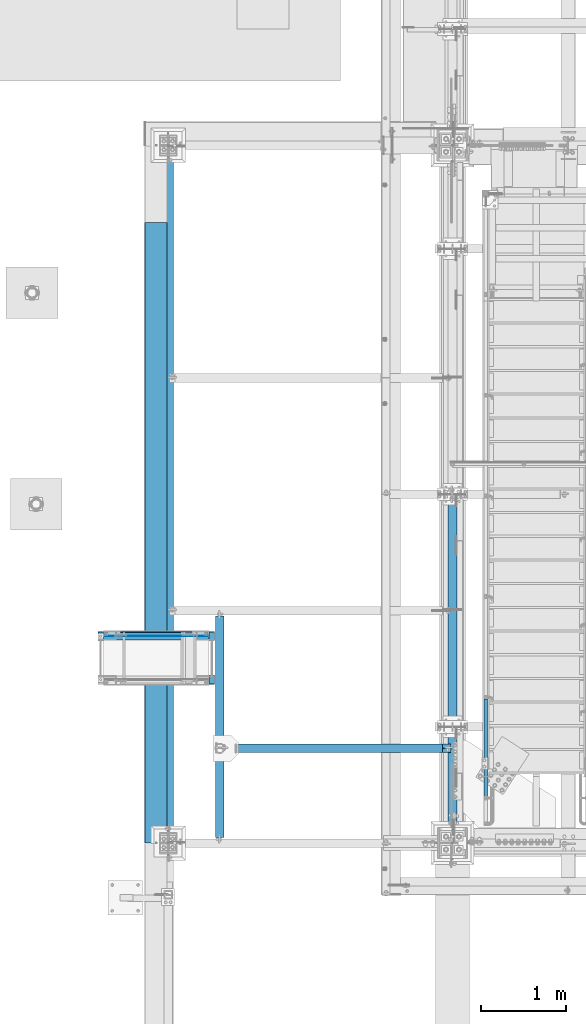
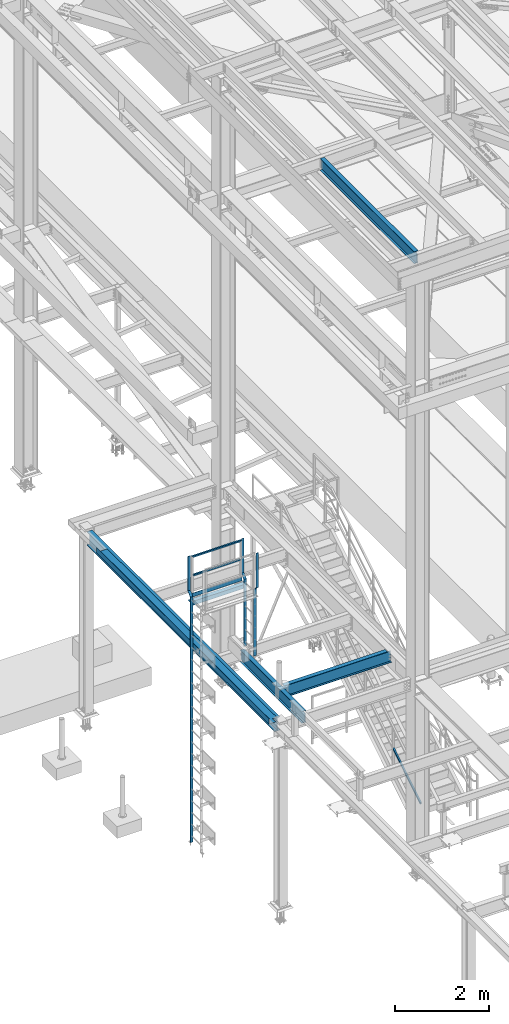
# One storey, part 1741 of 3843: 12 beams, 1 member, 9 elements without a shape of their own.
"""IFC2X3 building model written with IfcOpenShell, lengths in millimetres."""

from ifc_helpers import new_model, si_unit, frame, origin_with_axes, place, context, subcontext, project, spatial, faceted_brep, material, type_object, element, aggregate, save


model = new_model("IFC2X3")

# Units and contexts
model_context = context("Model", 3, precision=1e-05, world=origin_with_axes())
body_context = subcontext(model_context, "Body", "Model", "MODEL_VIEW")
ifc_project = project(units=[si_unit("LENGTHUNIT", "METRE", prefix="MILLI"), si_unit("AREAUNIT", "SQUARE_METRE"), si_unit("VOLUMEUNIT", "CUBIC_METRE"), si_unit("MASSUNIT", "GRAM", prefix="KILO"), si_unit("TIMEUNIT", "SECOND"), si_unit("PLANEANGLEUNIT", "RADIAN"), si_unit("SOLIDANGLEUNIT", "STERADIAN"), si_unit("THERMODYNAMICTEMPERATUREUNIT", "DEGREE_CELSIUS"), si_unit("LUMINOUSINTENSITYUNIT", "LUMEN")], contexts=[model_context])

# Site, building, storey
site_placement = place(None, origin_with_axes())
site = spatial("IfcSite", under=ifc_project, at=site_placement, CompositionType="ELEMENT")
building_placement = place(site_placement, origin_with_axes())
building = spatial("IfcBuilding", under=site, at=building_placement, Name="Undefined", CompositionType="ELEMENT")
storey_placement = place(building_placement, origin_with_axes())
storey = spatial("IfcBuildingStorey", under=building, at=storey_placement, Name="Undefined", CompositionType="ELEMENT", Elevation=0.0)

# Assembly, beams
assembly_1_placement = place(storey_placement, origin_with_axes())
assembly_1 = element("IfcElementAssembly", 1, at=assembly_1_placement, inside=storey, Name="RAIL", AssemblyPlace="NOTDEFINED", PredefinedType="RIGID_FRAME")
ifc_material_1 = material()
beam_type_1 = type_object("IfcBeamType", Name="HSS1-1/2X1-1/2X1/4", PredefinedType="NOTDEFINED")
beam_1_placement = place(assembly_1_placement, frame((32489.179674793, 28079.7, 37330.7272224447), z_axis=(0.0, -1.0, 0.0), x_axis=(1.0, 0.0, 0.0)))
beam_1 = element("IfcBeam", 2, at=beam_1_placement, type_object=beam_type_1, material=ifc_material_1, Name="RAIL", ObjectType="HSS1-1/2X1-1/2X1/4", context=body_context, shape_type="Brep", body=[
    faceted_brep([(19.0499992350015, 12.6999993299978, -12.6999993299978), (19.0499992350015, -12.6999993299978, -12.6999993299978), (1164.62970173694, -12.6999993299978, -12.6999993300014), (1164.62970173694, 12.6999993299978, -12.6999993300014), (19.0499992350015, -12.6999993299978, 12.6999993299978), (1164.62970173694, -12.6999993299978, 12.6999993300014), (19.0499992350015, 12.6999993299978, 12.6999993299978), (1164.62970173694, 12.6999993299978, 12.6999993300014), (19.0499992350015, 19.0499992350015, -19.0499992350015), (19.0499992350015, 19.0499992350015, 19.0499992350015), (1164.62970173694, 19.0499992350015, 19.0499992350015), (1164.62970173694, 19.0499992350015, -19.0499992350015), (19.0499992350015, -19.0499992350015, 19.0499992350015), (1164.62970173694, -19.0499992350015, 19.0499992350015), (19.0499992350015, -19.0499992350015, -19.0499992350015), (1164.62970173694, -19.0499992350015, -19.0499992350015)], [[[0, 1, 2, 3]], [[1, 4, 5, 2]], [[4, 6, 7, 5]], [[6, 0, 3, 7]], [[8, 9, 10, 11]], [[9, 12, 13, 10]], [[12, 14, 15, 13]], [[14, 8, 11, 15]], [[13, 15, 11, 10], [5, 7, 3, 2]], [[14, 12, 9, 8], [6, 4, 1, 0]]]),
])
beam_2_placement = place(assembly_1_placement, frame((32387.6686576823, 28079.6999999999, 37812.7905159017), z_axis=(0.0, -1.0, 0.0), x_axis=(1.0, 0.0, 0.0)))
beam_2 = element("IfcBeam", 3, at=beam_2_placement, type_object=beam_type_1, material=ifc_material_1, Name="RAIL", ObjectType="HSS1-1/2X1-1/2X1/4", context=body_context, shape_type="Brep", body=[
    faceted_brep([(88.8110177807284, 12.6999993299978, -12.6999993300014), (114.211016440731, -12.6999993299978, -12.6999993300014), (1272.49071875267, -12.6999993299978, -12.6999993300014), (1297.89071741267, 12.6999993299978, -12.6999993300014), (114.211016440731, -12.6999993299978, 12.6999993300014), (1272.49071875267, -12.6999993299978, 12.6999993300014), (88.8110177807284, 12.6999993299978, 12.6999993300014), (1297.89071741267, 12.6999993299978, 12.6999993300014), (82.4610178757284, 19.0499992350015, -19.0499992350015), (82.4610178757284, 19.0499992350015, 19.0499992350015), (1304.24071731767, 19.0499992350015, 19.0499992350015), (1304.24071731767, 19.0499992350015, -19.0499992350015), (120.561016345731, -19.0499992350015, 19.0499992350015), (1266.14071884767, -19.0499992350015, 19.0499992350015), (120.561016345731, -19.0499992350015, -19.0499992350015), (1266.14071884767, -19.0499992350015, -19.0499992350015)], [[[0, 1, 2, 3]], [[1, 4, 5, 2]], [[4, 6, 7, 5]], [[6, 0, 3, 7]], [[8, 9, 10, 11]], [[9, 12, 13, 10]], [[12, 14, 15, 13]], [[14, 8, 11, 15]], [[13, 15, 11, 10], [5, 7, 3, 2]], [[14, 12, 9, 8], [6, 4, 1, 0]]]),
])

# Assembly, member
assembly_2_placement = place(storey_placement, origin_with_axes())
assembly_2 = element("IfcElementAssembly", 4, at=assembly_2_placement, inside=storey, Name="RAIL", AssemblyPlace="NOTDEFINED", PredefinedType="RIGID_FRAME")
member_type = type_object("IfcMemberType", Name="HSS1-1/2X1-1/2X1/4", PredefinedType="NOTDEFINED")
member_placement = place(assembly_2_placement, frame((36969.699999953, 26149.3, 31013.4000000005), z_axis=(0.0, -0.529007926750979, 0.848616882600523), x_axis=(0.0, 0.848616882600524, 0.529007926750978)))
member = element("IfcMember", 5, at=member_placement, type_object=member_type, material=ifc_material_1, Name="RAIL", ObjectType="HSS1-1/2X1-1/2X1/4", context=body_context, shape_type="Brep", body=[
    faceted_brep([(1388.70393079125, -19.0500003643538, 19.0499992334262), (1364.95328239725, -19.0499992350015, -19.0499992364712), (1364.95328239725, 19.0499992350015, -19.0499992364712), (1388.70393079125, 19.0499992350015, 19.0499992334262), (1384.74548929282, -12.6999993299978, 12.699999328448), (1384.74548929282, 12.6999993299978, 12.699999328448), (1368.91172389637, 12.6999993299978, -12.6999993314894), (1368.91172389637, -12.6999993299978, -12.6999993314894), (10.5729683018217, 19.0499992350015, -19.0499992349742), (34.3236166958304, 19.0499992350015, 19.0499992349305), (34.3236166958304, -19.0500000222455, 19.0499992349305), (10.5729683018217, -19.0499992350015, -19.0499992349742), (30.3651751973375, -12.6999993299978, 12.6999993299451), (14.5314098008821, -12.6999993299978, -12.6999993299924), (14.5314098008821, 12.6999993299978, -12.6999993299924), (30.3651751973375, 12.6999993299978, 12.6999993299451)], [[[0, 1, 2, 3], [4, 5, 6, 7]], [[8, 9, 3, 2]], [[9, 10, 0, 3]], [[10, 11, 1, 0]], [[11, 8, 2, 1]], [[10, 9, 8, 11], [12, 13, 14, 15]], [[13, 12, 4, 7]], [[14, 13, 7, 6]], [[15, 14, 6, 5]], [[12, 15, 5, 4]]]),
])
aggregate(assembly_2, [member])

# Assembly, beams
assembly_3_placement = place(storey_placement, origin_with_axes())
assembly_3 = element("IfcElementAssembly", 6, at=assembly_3_placement, inside=storey, Name="LADDER", AssemblyPlace="NOTDEFINED", PredefinedType="RIGID_FRAME")
ifc_material_2 = material(Name="STEEL/A36")
beam_type_2 = type_object("IfcBeamType", PredefinedType="NOTDEFINED")
beam_3_placement = place(assembly_3_placement, frame((33736.4390258789, 28109.8624999999, 37831.8405151367), z_axis=(-1.0, 0.0, 0.0), x_axis=(0.0, 0.0, -1.0)))
beam_3 = element("IfcBeam", 7, at=beam_3_placement, type_object=beam_type_2, material=ifc_material_2, Name="LADDER", context=body_context, shape_type="Brep", body=[
    faceted_brep([(0.0, -4.76249999999709, -31.75), (0.0, -4.76249999999709, 31.75), (0.0, 4.76249999999709, 31.75), (0.0, 4.76249999999709, -31.75), (888.999999999985, 4.76249999999709, 31.75), (888.999999999985, 4.76249999999709, -31.75), (892.945384181585, -4.76249999999709, -31.75), (892.945384181585, -4.76249999999709, 31.75), (990.599999999991, 106.362500000003, 31.75), (990.599999999991, 106.362500000003, -31.75), (994.545384181591, 96.8375000000087, -31.75), (994.545384181591, 96.8375000000087, 31.75), (2723.62203281296, 106.362499999999, 31.75), (2723.62203281296, 106.362499999999, -31.75), (2723.62203281296, 96.8374999999978, 31.75), (2723.62203281296, 96.8374999999978, -31.75)], [[[0, 1, 2, 3]], [[3, 2, 4, 5]], [[1, 0, 6, 7]], [[5, 4, 8, 9]], [[7, 6, 10, 11]], [[9, 8, 12, 13]], [[8, 4, 2, 1, 7, 11, 14, 12]], [[11, 10, 15, 14]], [[10, 6, 0, 3, 5, 9, 13, 15]], [[14, 15, 13, 12]]]),
])
beam_4_placement = place(assembly_3_placement, frame((33736.4390258789, 27592.3374999999, 35108.2184823238), z_axis=(-1.0, 0.0, 0.0), x_axis=(0.0, 0.0, 1.0)))
beam_4 = element("IfcBeam", 8, at=beam_4_placement, type_object=beam_type_2, material=ifc_material_2, Name="LADDER", context=body_context, shape_type="Brep", body=[
    faceted_brep([(0.0, -4.76249999999709, -31.75), (0.0, -4.76249999999709, 31.75), (0.0, 4.76249999999709, 31.75), (0.0, 4.76249999999709, -31.75), (1733.02203281297, 4.76250000000073, 31.75), (1733.02203281297, 4.76250000000073, -31.75), (1729.07664863137, -4.76250000000073, -31.75), (1729.07664863137, -4.76250000000073, 31.75), (1834.62203281298, -96.8374999999978, 31.75), (1834.62203281298, -96.8374999999978, -31.75), (1830.67664863138, -106.362499999999, -31.75), (1830.67664863138, -106.362499999999, 31.75), (2723.62203281296, -96.8374999999978, 31.75), (2723.62203281296, -96.8374999999978, -31.75), (2723.62203281296, -106.362499999999, 31.75), (2723.62203281296, -106.362499999999, -31.75)], [[[0, 1, 2, 3]], [[3, 2, 4, 5]], [[1, 0, 6, 7]], [[5, 4, 8, 9]], [[7, 6, 10, 11]], [[9, 8, 12, 13]], [[8, 4, 2, 1, 7, 11, 14, 12]], [[11, 10, 15, 14]], [[10, 6, 0, 3, 5, 9, 13, 15]], [[14, 15, 13, 12]]]),
])
aggregate(assembly_3, [beam_3, beam_4])

# Assembly, beam
assembly_4_placement = place(storey_placement, origin_with_axes())
assembly_4 = element("IfcElementAssembly", 9, at=assembly_4_placement, inside=storey, Name="LADDER", AssemblyPlace="NOTDEFINED", PredefinedType="RIGID_FRAME")
beam_5_placement = place(assembly_4_placement, frame((32425.7733459473, 28008.2624999999, 30492.7), z_axis=(1.0, 0.0, 0.0), x_axis=(0.0, 0.0, 1.0)))
beam_5 = element("IfcBeam", 10, at=beam_5_placement, type_object=beam_type_2, material=ifc_material_2, Name="LADDER", context=body_context, shape_type="Brep", body=[
    faceted_brep([(0.0, -4.76249999999709, -31.75), (0.0, -4.76249999999709, 31.75), (0.0, 4.76249999999709, 31.75), (0.0, 4.76249999999709, -31.75), (6348.54051513673, 4.76250000000073, 31.75), (6348.54051513673, 4.76250000000073, -31.75), (6344.59513095513, -4.76250000000073, -31.75), (6344.59513095513, -4.76250000000073, 31.75), (6450.14051513673, -96.8374999999978, 31.75), (6450.14051513673, -96.8374999999978, -31.75), (6446.19513095513, -106.362499999999, -31.75), (6446.19513095513, -106.362499999999, 31.75), (7339.14051513672, -96.8374999999978, 31.75), (7339.14051513672, -96.8374999999978, -31.75), (7339.14051513672, -106.362499999999, 31.75), (7339.14051513672, -106.362499999999, -31.75)], [[[0, 1, 2, 3]], [[3, 2, 4, 5]], [[1, 0, 6, 7]], [[5, 4, 8, 9]], [[7, 6, 10, 11]], [[9, 8, 12, 13]], [[8, 4, 2, 1, 7, 11, 14, 12]], [[11, 10, 15, 14]], [[10, 6, 0, 3, 5, 9, 13, 15]], [[14, 15, 13, 12]]]),
])
aggregate(assembly_4, [beam_5])

# Beam
beam_type_3 = type_object("IfcBeamType", PredefinedType="NOTDEFINED")
beam_6_placement = place(assembly_1_placement, frame((32470.2063863546, 28057.475000765, 36835.4260559082), z_axis=(0.0, 0.0, 1.0), x_axis=(1.0, 0.0, 0.0)))
beam_6 = element("IfcBeam", 11, at=beam_6_placement, type_object=beam_type_3, material=ifc_material_2, Name="TOE_PLATE", context=body_context, shape_type="Brep", body=[
    faceted_brep([(0.0, 3.17500000000291, -50.8000000000029), (0.0, 3.17500000000291, 50.8000000000029), (1221.7796976298, 3.17499999999927, 50.8000000000029), (1221.7796976298, 3.17499999999927, -50.8000000000029), (0.0, -3.17500000000291, 50.8000000000029), (1221.7796976298, -3.17499999999927, 50.8000000000029), (0.0, -3.17500000000291, -50.8000000000029), (1221.7796976298, -3.17499999999927, -50.8000000000029)], [[[0, 1, 2, 3]], [[1, 4, 5, 2]], [[4, 6, 7, 5]], [[6, 0, 3, 7]], [[5, 7, 3, 2]], [[6, 4, 1, 0]]]),
])

aggregate(assembly_1, [beam_6, beam_1, beam_2])

# Assembly, beam
assembly_5_placement = place(storey_placement, origin_with_axes())
assembly_5 = element("IfcElementAssembly", 12, at=assembly_5_placement, inside=storey, Name="ANGLE", AssemblyPlace="NOTDEFINED", PredefinedType="RIGID_FRAME")
beam_type_4 = type_object("IfcBeamType", Name="L4X4X3/8", PredefinedType="NOTDEFINED")
beam_7_placement = place(assembly_5_placement, frame((32400.3733459473, 28063.8249999999, 36651.275958252), z_axis=(0.0, 0.0, -1.0), x_axis=(1.0, 0.0, 0.0)))
beam_7 = element("IfcBeam", 13, at=beam_7_placement, type_object=beam_type_4, material=ifc_material_2, Name="ANGLE", ObjectType="L4X4X3/8", context=body_context, shape_type="Brep", body=[
    faceted_brep([(0.0, 50.8000000000029, -50.8000000000029), (0.0, 50.8000000000029, 50.8000000000029), (1361.47970020696, 50.7999999999993, 50.8000000000029), (1361.47970020696, 50.7999999999993, -50.8000000000029), (0.0, 41.2750000000015, 50.8000000000029), (1361.47970020696, 41.2750000000015, 50.8000000000029), (0.0, 41.2749999999942, -41.2750000000015), (1361.47970020696, 41.2750000000015, -41.2750000000015), (0.0, -50.8000000000029, -41.2750000000015), (1361.47970020696, -50.7999999999993, -41.2750000000015), (0.0, -50.8000000000029, -50.8000000000029), (1361.47970020696, -50.7999999999993, -50.8000000000029)], [[[0, 1, 2, 3]], [[1, 4, 5, 2]], [[4, 6, 7, 5]], [[6, 8, 9, 7]], [[8, 10, 11, 9]], [[10, 0, 3, 11]], [[5, 7, 9, 11, 3, 2]], [[10, 8, 6, 4, 1, 0]]]),
])
aggregate(assembly_5, [beam_7])

assembly_6_placement = place(storey_placement, origin_with_axes())
assembly_6 = element("IfcElementAssembly", 14, at=assembly_6_placement, inside=storey, Name="BEAM", AssemblyPlace="NOTDEFINED", PredefinedType="RIGID_FRAME")
ifc_material_3 = material(Name="STEEL/A992")
beam_type_5 = type_object("IfcBeamType", Name="W12X19", PredefinedType="NOTDEFINED")
beam_8_placement = place(assembly_6_placement, frame((33832.8, 26733.5, 34656.7125), z_axis=(0.0, 0.0, 1.0), x_axis=(1.0, 0.0, 0.0)))
beam_8 = element("IfcBeam", 15, at=beam_8_placement, type_object=beam_type_5, material=ifc_material_3, Name="BEAM", ObjectType="W12X19", context=body_context, shape_type="Brep", body=[
    faceted_brep([(15.8750000000146, -3.17500000000291, -128.587499998961), (15.8750000000146, 3.17500000000291, -128.587499998961), (92.0750001907509, 3.17499999999927, -128.587499999987), (92.0750001907509, -3.17499999999927, -128.587499999987), (96.9350797087973, 3.17499999999927, -129.554229922578), (96.9350797087973, -3.17499999999927, -129.554229922578), (101.055256176951, 3.17499999999927, -132.307243823052), (101.055256176951, -3.17499999999927, -132.307243823052), (103.808270077425, 3.17499999999927, -136.427420291206), (103.808270077425, -3.17499999999927, -136.427420291206), (104.775000000016, -3.17499999999927, -141.287499809252), (104.775000000016, 3.17499999999927, -141.287499809252), (104.775000000016, 3.17499999999927, -144.462500000001), (104.775000000016, 50.7999999999993, -144.462500000001), (104.775000000016, 50.7999999999993, -153.987500000003), (104.775000000016, -50.7999999999993, -153.987500000003), (104.775000000016, -50.7999999999993, -144.462500000001), (104.775000000016, -3.17499999999927, -144.462500000001), (2624.1375, 50.7999999999993, 144.462500000001), (2624.1375, 3.17499999999927, 144.462500000001), (104.775000000016, 3.17499999999927, 144.462500000001), (104.775000000016, 50.7999999999993, 144.462500000001), (92.0750001907509, -3.17499999999927, 128.587500000016), (92.0750001907509, 3.17499999999927, 128.587500000016), (15.8750000000146, 3.17500000000291, 128.587500001042), (15.8750000000146, -3.17500000000291, 128.587500001042), (96.9350797087973, -3.17499999999927, 129.554229922607), (96.9350797087973, 3.17499999999927, 129.554229922607), (101.055256176951, -3.17499999999927, 132.307243823081), (101.055256176951, 3.17499999999927, 132.307243823081), (103.808270077425, -3.17499999999927, 136.427420291235), (103.808270077425, 3.17499999999927, 136.427420291235), (104.775000000016, -3.17499999999927, 141.287499809281), (104.775000000016, 3.17499999999927, 141.287499809281), (2624.1375, -50.7999999999993, 153.987500000003), (2624.1375, 50.7999999999993, 153.987500000003), (104.775000000016, 50.7999999999993, 153.987500000003), (104.775000000016, -50.7999999999993, 153.987500000003), (2624.1375, -50.7999999999993, 144.462500000001), (104.775000000016, -50.7999999999993, 144.462500000001), (2624.1375, -3.17499999999927, 144.462500000001), (104.775000000016, -3.17499999999927, 144.462500000001), (2624.1375, -3.17499999999927, 134.937499809261), (2624.1375, 3.17499999999927, 134.937499809261), (2625.1042299226, -3.17499999999927, 130.077420291214), (2625.1042299226, 3.17499999999927, 130.077420291214), (2627.85724382307, -3.17499999999927, 125.957243823061), (2627.85724382307, 3.17499999999927, 125.957243823061), (2631.97742029122, -3.17499999999927, 123.204229922587), (2631.97742029122, 3.17499999999927, 123.204229922587), (2636.83749980927, -3.17499999999927, 122.237499999996), (2636.83749980927, 3.17499999999927, 122.237499999996), (2725.73750000001, -3.17499999999927, 122.237499999996), (2725.73750000001, 3.17499999999927, 122.237499999996), (2725.73750000001, -3.17499999999927, -144.462500000001), (2725.73750000001, -50.7999999999993, -144.462500000001), (2725.73750000001, -50.7999999999993, -153.987500000003), (2725.73750000001, 50.7999999999993, -153.987500000003), (2725.73750000001, 50.7999999999993, -144.462500000001), (2725.73750000001, 3.17499999999927, -144.462500000001), (2725.73750000001, 3.17499999999927, -114.712500000001), (2725.73750000001, 3.17499999999927, 115.887499999997)], [[[0, 1, 2, 3]], [[3, 2, 4, 5]], [[5, 4, 6, 7]], [[7, 6, 8, 9]], [[10, 11, 12, 13, 14, 15, 16, 17]], [[9, 8, 11, 10]], [[18, 19, 20, 21]], [[22, 23, 24, 25]], [[26, 27, 23, 22]], [[28, 29, 27, 26]], [[30, 31, 29, 28]], [[32, 33, 31, 30]], [[34, 35, 36, 37]], [[38, 34, 37, 39]], [[40, 38, 39, 41]], [[37, 36, 21, 20, 33, 32, 41, 39]], [[35, 18, 21, 36]], [[34, 38, 40, 42, 43, 19, 18, 35]], [[44, 45, 43, 42]], [[46, 47, 45, 44]], [[48, 49, 47, 46]], [[50, 51, 49, 48]], [[52, 53, 51, 50]], [[54, 55, 56, 57, 58, 59, 60, 61, 53, 52]], [[55, 54, 17, 16]], [[56, 55, 16, 15]], [[57, 56, 15, 14]], [[58, 57, 14, 13]], [[59, 58, 13, 12]], [[6, 4, 2, 1, 24, 23, 27, 29, 31, 33, 20, 19, 43, 45, 47, 49, 51, 53, 61, 60, 59, 12, 11, 8]], [[25, 24, 1, 0]], [[54, 52, 50, 48, 46, 44, 42, 40, 41, 32, 30, 28, 26, 22, 25, 0, 3, 5, 7, 9, 10, 17]]]),
])
aggregate(assembly_6, [beam_8])

assembly_7_placement = place(storey_placement, origin_with_axes())
assembly_7 = element("IfcElementAssembly", 16, at=assembly_7_placement, inside=storey, Name="BEAM", AssemblyPlace="NOTDEFINED", PredefinedType="RIGID_FRAME")
beam_9_placement = place(assembly_7_placement, frame((33832.8, 25615.9, 34656.7125), z_axis=(0.0, 0.0, 1.0), x_axis=(0.0, 1.0, 0.0)))
beam_9 = element("IfcBeam", 17, at=beam_9_placement, type_object=beam_type_5, material=ifc_material_3, Name="BEAM", ObjectType="W12X19", context=body_context, shape_type="Brep", body=[
    faceted_brep([(2679.69999999999, -3.17500000000291, -144.462500000001), (2679.69999999999, -50.8000000000029, -144.462500000001), (2679.69999999999, -50.8000000000029, -153.987500000003), (2679.69999999999, 50.8000000000029, -153.987500000003), (2679.69999999999, 50.8000000000029, -144.462500000001), (2679.69999999999, 3.17500000000291, -144.462500000001), (2679.69999999999, 3.17500000000291, -141.287499809252), (2679.69999999999, -3.17500000000291, -141.287499809252), (2680.66672992258, 3.17500000000291, -136.427420291206), (2680.66672992258, -3.17500000000291, -136.427420291206), (2683.41974382306, 3.17500000000291, -132.307243823052), (2683.41974382306, -3.17500000000291, -132.307243823052), (2687.53992029121, 3.17500000000291, -129.554229922578), (2687.53992029121, -3.17500000000291, -129.554229922578), (2692.39999980926, 3.17500000000291, -128.587499999987), (2692.39999980926, -3.17500000000291, -128.587499999987), (2727.32499999999, -3.17500000000291, -128.587499999987), (2727.32499999999, 3.17500000000291, -128.587499999987), (2679.69999999999, 50.8000000000029, 144.462500000001), (2679.69999999999, 3.17500000000291, 144.462500000001), (63.4999999999927, 3.17500000000291, 144.462500000001), (63.4999999999927, 50.8000000000029, 144.462500000001), (63.4999999999927, -3.17500000000291, -141.287499809267), (63.4999999999927, 3.17500000000291, -141.287499809267), (63.4999999999927, 3.17500000000291, -144.462500000001), (63.4999999999927, 50.8000000000029, -144.462500000001), (63.4999999999927, 50.8000000000029, -153.987500000003), (63.4999999999927, -50.8000000000029, -153.987500000003), (63.4999999999927, -50.8000000000029, -144.462500000001), (63.4999999999927, -3.17500000000291, -144.462500000001), (62.5332700774052, -3.17500000000291, -136.42742029122), (62.5332700774052, 3.17500000000291, -136.42742029122), (59.7802561769277, -3.17500000000291, -132.307243823067), (59.7802561769277, 3.17500000000291, -132.307243823067), (55.660079708774, -3.17500000000291, -129.554229922593), (55.660079708774, 3.17500000000291, -129.554229922593), (50.8000001907276, -3.17500000000291, -128.587500000001), (50.8000001907276, 3.17500000000291, -128.587500000001), (15.8750000000146, -3.17500000000291, -128.587499998961), (15.8750000000146, 3.17500000000291, -128.587499998961), (15.8750000000146, -3.17500000000291, 128.587500001042), (15.8750000000146, 3.17500000000291, 128.587500001042), (15.8750000000146, 3.17500000000291, 115.887500001612), (15.8750000000146, 3.17500000000291, -114.712499998386), (50.8000001907276, -3.17500000000291, 128.587500000001), (50.8000001907276, 3.17500000000291, 128.587500000001), (55.660079708774, -3.17500000000291, 129.554229922593), (55.660079708774, 3.17500000000291, 129.554229922593), (59.7802561769277, -3.17500000000291, 132.307243823067), (59.7802561769277, 3.17500000000291, 132.307243823067), (62.5332700774052, -3.17500000000291, 136.42742029122), (62.5332700774052, 3.17500000000291, 136.42742029122), (63.4999999999927, -3.17500000000291, 141.287499809267), (63.4999999999927, 3.17500000000291, 141.287499809267), (2679.69999999999, -50.8000000000029, 153.987500000003), (2679.69999999999, 50.8000000000029, 153.987500000003), (63.4999999999927, 50.8000000000029, 153.987500000003), (63.4999999999927, -50.8000000000029, 153.987500000003), (2679.69999999999, -50.8000000000029, 144.462500000001), (63.4999999999927, -50.8000000000029, 144.462500000001), (2679.69999999999, -3.17500000000291, 144.462500000001), (63.4999999999927, -3.17500000000291, 144.462500000001), (2679.69999999999, -3.17500000000291, 141.287499809281), (2679.69999999999, 3.17500000000291, 141.287499809281), (2680.66672992258, -3.17500000000291, 136.427420291235), (2680.66672992258, 3.17500000000291, 136.427420291235), (2683.41974382306, -3.17500000000291, 132.307243823081), (2683.41974382306, 3.17500000000291, 132.307243823081), (2687.53992029121, -3.17500000000291, 129.554229922607), (2687.53992029121, 3.17500000000291, 129.554229922607), (2692.39999980926, -3.17500000000291, 128.587500000016), (2692.39999980926, 3.17500000000291, 128.587500000016), (2727.32499999999, -3.17500000000291, 128.587500000016), (2727.32499999999, 3.17500000000291, 128.587500000016), (2727.32499999999, 3.17500000000291, -114.712500000001), (2727.32499999999, 3.17500000000291, 115.887499999997)], [[[0, 1, 2, 3, 4, 5, 6, 7]], [[7, 6, 8, 9]], [[9, 8, 10, 11]], [[11, 10, 12, 13]], [[13, 12, 14, 15]], [[16, 15, 14, 17]], [[18, 19, 20, 21]], [[22, 23, 24, 25, 26, 27, 28, 29]], [[30, 31, 23, 22]], [[32, 33, 31, 30]], [[34, 35, 33, 32]], [[36, 37, 35, 34]], [[38, 39, 37, 36]], [[40, 41, 42, 43, 39, 38]], [[44, 45, 41, 40]], [[46, 47, 45, 44]], [[48, 49, 47, 46]], [[50, 51, 49, 48]], [[52, 53, 51, 50]], [[54, 55, 56, 57]], [[58, 54, 57, 59]], [[60, 58, 59, 61]], [[57, 56, 21, 20, 53, 52, 61, 59]], [[55, 18, 21, 56]], [[54, 58, 60, 62, 63, 19, 18, 55]], [[64, 65, 63, 62]], [[66, 67, 65, 64]], [[68, 69, 67, 66]], [[70, 71, 69, 68]], [[72, 73, 71, 70]], [[74, 75, 73, 72, 16, 17]], [[12, 10, 8, 6, 5, 24, 23, 31, 33, 35, 37, 39, 43, 42, 41, 45, 47, 49, 51, 53, 20, 19, 63, 65, 67, 69, 71, 73, 75, 74, 17, 14]], [[25, 24, 5, 4]], [[26, 25, 4, 3]], [[27, 26, 3, 2]], [[28, 27, 2, 1]], [[29, 28, 1, 0]], [[72, 70, 68, 66, 64, 62, 60, 61, 52, 50, 48, 46, 44, 40, 38, 36, 34, 32, 30, 22, 29, 0, 7, 9, 11, 13, 15, 16]]]),
])
aggregate(assembly_7, [beam_9])

assembly_8_placement = place(storey_placement, origin_with_axes())
assembly_8 = element("IfcElementAssembly", 18, at=assembly_8_placement, inside=storey, Name="BEAM", AssemblyPlace="NOTDEFINED", PredefinedType="RIGID_FRAME")
beam_10_placement = place(assembly_8_placement, frame((36575.9999999188, 25485.725, 45575.6071293685), z_axis=(0.0, 0.0, 1.0), x_axis=(0.0, 1.0, 0.0)))
beam_10 = element("IfcBeam", 19, at=beam_10_placement, type_object=beam_type_5, material=ifc_material_3, Name="BEAM", ObjectType="W12X19", context=body_context, shape_type="Brep", body=[
    faceted_brep([(146.049999999974, -3.17500000000291, -128.587499998903), (146.049999999974, 3.17500000000291, -128.587499998903), (184.150000190708, 3.17500000000291, -128.587499998903), (184.150000190708, -3.17500000000291, -128.587499998903), (189.010079708754, 3.17500000000291, -129.554229921494), (189.010079708754, -3.17500000000291, -129.554229921494), (193.130256176908, 3.17500000000291, -132.307243821968), (193.130256176908, -3.17500000000291, -132.307243821968), (195.883270077386, 3.17500000000291, -136.427420290122), (195.883270077386, -3.17500000000291, -136.427420290122), (196.849999999973, -3.17500000000291, -141.287499808168), (196.849999999973, 3.17500000000291, -141.287499808168), (196.849999999973, 3.17500000000291, -144.462500000001), (196.849999999973, 50.8000000000029, -144.462500000001), (196.849999999973, 50.8000000000029, -153.987500000003), (196.849999999973, -50.8000000000029, -153.987500000003), (196.849999999973, -50.8000000000029, -144.462500000001), (196.849999999973, -3.17500000000291, -144.462500000001), (4178.29999999988, 50.8000000000029, 144.462500000001), (4178.29999999988, 3.17500000000291, 144.462500000001), (196.849999999973, 3.17500000000291, 144.462500000001), (196.849999999973, 50.8000000000029, 144.462500000001), (184.150000190708, -3.17500000000291, 128.5875000011), (184.150000190708, 3.17500000000291, 128.5875000011), (146.049999999974, 3.17500000000291, 128.5875000011), (146.049999999974, -3.17500000000291, 128.5875000011), (189.010079708754, -3.17500000000291, 129.554229923691), (189.010079708754, 3.17500000000291, 129.554229923691), (193.130256176908, -3.17500000000291, 132.307243824165), (193.130256176908, 3.17500000000291, 132.307243824165), (195.883270077386, -3.17500000000291, 136.427420292319), (195.883270077386, 3.17500000000291, 136.427420292319), (196.849999999973, -3.17500000000291, 141.287499810365), (196.849999999973, 3.17500000000291, 141.287499810365), (4178.29999999988, -50.8000000000029, 153.987500000003), (4178.29999999988, 50.8000000000029, 153.987500000003), (196.849999999973, 50.8000000000029, 153.987500000003), (196.849999999973, -50.8000000000029, 153.987500000003), (4178.29999999988, -50.8000000000029, 144.462500000001), (196.849999999973, -50.8000000000029, 144.462500000001), (4178.29999999988, -3.17500000000291, 144.462500000001), (196.849999999973, -3.17500000000291, 144.462500000001), (4178.29999999988, -3.17500000000291, 141.287499810365), (4178.29999999988, 3.17500000000291, 141.287499810365), (4179.26672992246, -3.17500000000291, 136.427420292319), (4179.26672992246, 3.17500000000291, 136.427420292319), (4182.01974382294, -3.17500000000291, 132.307243824165), (4182.01974382294, 3.17500000000291, 132.307243824165), (4186.13992029109, -3.17500000000291, 129.554229923691), (4186.13992029109, 3.17500000000291, 129.554229923691), (4190.99999980914, -3.17500000000291, 128.5875000011), (4190.99999980914, 3.17500000000291, 128.5875000011), (4229.09999999987, -3.17500000000291, 128.5875000011), (4229.09999999987, 3.17500000000291, 128.5875000011), (4229.09999999987, 3.17500000000291, -114.712499998386), (4229.09999999987, 3.17500000000291, 115.887500001612), (4229.09999999987, -3.17500000000291, -128.587499998903), (4229.09999999987, 3.17500000000291, -128.587499998903), (4190.99999980914, -3.17500000000291, -128.587499998903), (4190.99999980914, 3.17500000000291, -128.587499998903), (4186.13992029109, -3.17500000000291, -129.554229921494), (4186.13992029109, 3.17500000000291, -129.554229921494), (4182.01974382294, -3.17500000000291, -132.307243821968), (4182.01974382294, 3.17500000000291, -132.307243821968), (4179.26672992246, -3.17500000000291, -136.427420290122), (4179.26672992246, 3.17500000000291, -136.427420290122), (4178.29999999988, -3.17500000000291, -141.287499808168), (4178.29999999988, 3.17500000000291, -141.287499808168), (4178.29999999988, -3.17500000000291, -144.462500000001), (4178.29999999988, -50.8000000000029, -144.462500000001), (4178.29999999988, -50.8000000000029, -153.987500000003), (4178.29999999988, 50.8000000000029, -153.987500000003), (4178.29999999988, 50.8000000000029, -144.462500000001), (4178.29999999988, 3.17500000000291, -144.462500000001), (146.049999999974, 3.17500000000291, -114.712499998386), (146.049999999974, 3.17500000000291, 115.887500001612)], [[[0, 1, 2, 3]], [[3, 2, 4, 5]], [[5, 4, 6, 7]], [[7, 6, 8, 9]], [[10, 11, 12, 13, 14, 15, 16, 17]], [[9, 8, 11, 10]], [[18, 19, 20, 21]], [[22, 23, 24, 25]], [[26, 27, 23, 22]], [[28, 29, 27, 26]], [[30, 31, 29, 28]], [[32, 33, 31, 30]], [[34, 35, 36, 37]], [[38, 34, 37, 39]], [[40, 38, 39, 41]], [[37, 36, 21, 20, 33, 32, 41, 39]], [[35, 18, 21, 36]], [[34, 38, 40, 42, 43, 19, 18, 35]], [[44, 45, 43, 42]], [[46, 47, 45, 44]], [[48, 49, 47, 46]], [[50, 51, 49, 48]], [[52, 53, 51, 50]], [[54, 55, 53, 52, 56, 57]], [[56, 58, 59, 57]], [[60, 61, 59, 58]], [[62, 63, 61, 60]], [[64, 65, 63, 62]], [[66, 67, 65, 64]], [[68, 69, 70, 71, 72, 73, 67, 66]], [[69, 68, 17, 16]], [[70, 69, 16, 15]], [[71, 70, 15, 14]], [[72, 71, 14, 13]], [[73, 72, 13, 12]], [[6, 4, 2, 1, 74, 75, 24, 23, 27, 29, 31, 33, 20, 19, 43, 45, 47, 49, 51, 53, 55, 54, 57, 59, 61, 63, 65, 67, 73, 12, 11, 8]], [[25, 24, 75, 74, 1, 0]], [[68, 66, 64, 62, 60, 58, 56, 52, 50, 48, 46, 44, 42, 40, 41, 32, 30, 28, 26, 22, 25, 0, 3, 5, 7, 9, 10, 17]]]),
])
aggregate(assembly_8, [beam_10])

# Assembly, beams
assembly_9_placement = place(storey_placement, origin_with_axes())
assembly_9 = element("IfcElementAssembly", 20, at=assembly_9_placement, inside=storey, Name="BEAM", AssemblyPlace="NOTDEFINED", PredefinedType="RIGID_FRAME")
beam_type_6 = type_object("IfcBeamType", PredefinedType="NOTDEFINED")
beam_11_placement = place(assembly_9_placement, frame((33210.5, 29276.6745, 34813.875), z_axis=(0.0, -1.0, 0.0), x_axis=(-1.0, 0.0, 0.0)))
beam_11 = element("IfcBeam", 21, at=beam_11_placement, type_object=beam_type_6, material=ifc_material_2, Name="BENT_PLATE", context=body_context, shape_type="Brep", body=[
    faceted_brep([(101.599999999999, -3.17500000000291, 3522.662), (101.599999999999, 3.17500000000291, 3522.662), (0.0, 3.17500000000291, 3522.66200000001), (0.0, -3.17500000000291, 3522.66200000001), (101.599999999984, -3.17500000000291, 3657.60000000001), (101.599999999984, 3.17500000000291, 3657.6), (260.350012207025, -3.17500000000291, -3657.6), (0.0, -3.17500000000291, -3657.6), (0.0, 3.17500000000291, -3657.6), (266.700012207031, 3.17500000000291, -3657.6), (266.700012207031, -136.524996948239, -3657.6), (260.350012207025, -136.524996948239, -3657.6), (266.700012207031, 3.17500000000291, 3657.6), (266.700012207031, -136.524996948239, 3657.6), (260.350012207025, -136.524996948239, 3657.6), (260.350012207025, -3.17500000000291, 3657.6)], [[[0, 1, 2, 3]], [[4, 5, 1, 0]], [[6, 7, 8, 9, 10, 11]], [[9, 12, 13, 10]], [[14, 11, 10, 13]], [[15, 6, 11, 14]], [[3, 7, 6, 15, 4, 0]], [[8, 7, 3, 2]], [[12, 9, 8, 2, 1, 5]], [[15, 14, 13, 12, 5, 4]]]),
])
beam_type_7 = type_object("IfcBeamType", Name="W14X26", PredefinedType="NOTDEFINED")
beam_12_placement = place(assembly_9_placement, frame((33223.2, 25615.9, 34634.4875), z_axis=(0.0, 0.0, 1.0), x_axis=(0.0, 1.0, 0.0)))
beam_12 = element("IfcBeam", 22, at=beam_12_placement, type_object=beam_type_7, material=ifc_material_3, Name="BEAM", ObjectType="W14X26", context=body_context, shape_type="Brep", body=[
    faceted_brep([(138.112499999999, -63.5, -176.212500000001), (138.112499999999, 63.5, -176.212500000001), (8091.48749999999, 63.5, -176.212500000001), (8091.48749999999, -63.5, -176.212500000001), (138.112499999999, -63.5, -165.099999999999), (138.112499999999, -3.17500000000291, -165.099999999999), (138.112499999999, -3.17500000000291, 165.099999999999), (138.112499999999, -63.5, 165.099999999999), (138.112499999999, -63.5, 176.212500000001), (138.112499999999, 63.5, 176.212500000001), (138.112499999999, 63.5, 165.099999999999), (138.112499999999, 3.17500000000291, 165.099999999999), (138.112499999999, 3.17500000000291, -165.099999999999), (138.112499999999, 63.5, -165.099999999999), (8091.48749999999, -63.5, -165.099999999999), (8091.48749999999, -3.17500000000291, -165.099999999999), (8091.48749999999, -3.17500000000291, 165.099999999999), (8091.48749999999, -63.5, 165.099999999999), (8091.48749999999, -63.5, 176.212500000001), (8091.48749999999, 63.5, 176.212500000001), (8091.48749999999, 63.5, 165.099999999999), (8091.48749999999, 3.17500000000291, 165.099999999999), (8091.48749999999, 3.17500000000291, -165.099999999999), (8091.48749999999, 63.5, -165.099999999999)], [[[0, 1, 2, 3]], [[0, 4, 5, 6, 7, 8, 9, 10, 11, 12, 13, 1]], [[5, 4, 14, 15]], [[6, 5, 15, 16]], [[7, 6, 16, 17]], [[8, 7, 17, 18]], [[9, 8, 18, 19]], [[10, 9, 19, 20]], [[11, 10, 20, 21]], [[12, 11, 21, 22]], [[13, 12, 22, 23]], [[1, 13, 23, 2]], [[22, 21, 20, 19, 18, 17, 16, 15, 14, 3, 2, 23]], [[4, 0, 3, 14]]]),
])
aggregate(assembly_9, [beam_11, beam_12])

save(model, "model.ifc")
